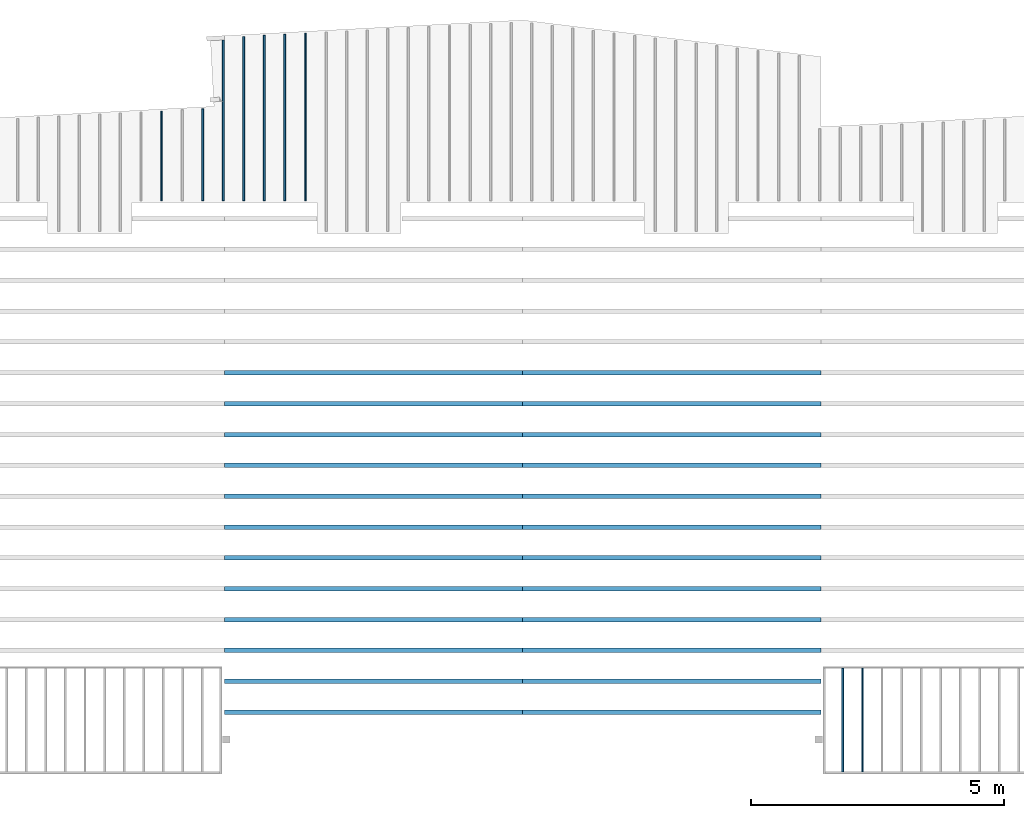
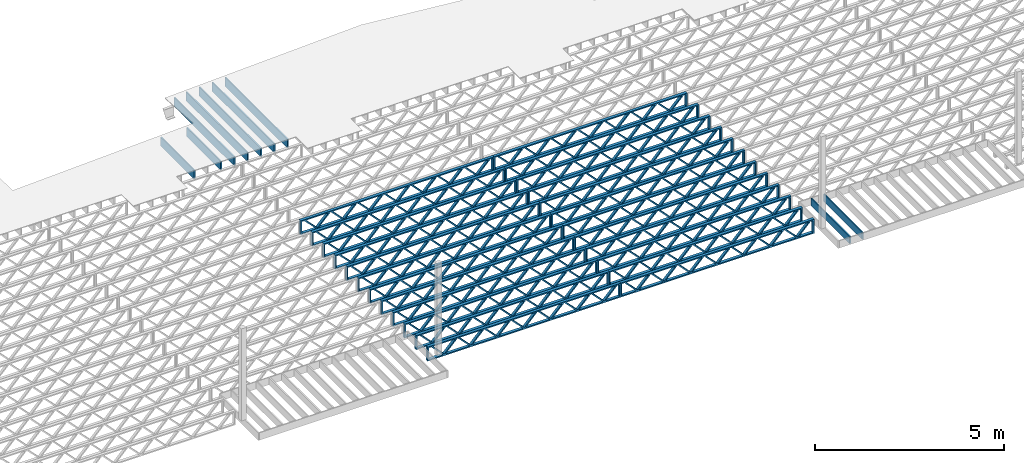
# One storey, part 6 of 13: 33 beams, 4 elements without a shape of their own.
"""IFC4 building model written with IfcOpenShell, lengths in feet."""

from ifc_helpers import new_model, entity, si_unit, converted_unit, derived_unit, direction, frame, frame_2d, origin, origin_2d_with_axis, place, context, subcontext, project, spatial, rectangle, extrude, source, transform, mapped, material, material_profile, profile_set, profile_usage, type_object, type_shapes, element, aggregate, save


model = new_model("IFC4")

# Units and contexts
model_context_1 = context("Model", 3, precision=0.0001, world=origin(), true_north=direction((6.12303176911189e-17, 1.0)))
model_context_2 = context("Model", 3, precision=0.0001, world=origin(), true_north=direction((6.12303176911189e-17, 1.0)))
body_context = subcontext(model_context_2, "Body", "Model", "MODEL_VIEW")
ifc_project = project(units=[converted_unit("LENGTHUNIT", "FOOT", entity("IfcRatioMeasure", 0.3048), si_unit("LENGTHUNIT", "METRE"), dimensions=[1, 0, 0, 0, 0, 0, 0]), converted_unit("AREAUNIT", "SQUARE FOOT", entity("IfcRatioMeasure", 0.09290304), si_unit("AREAUNIT", "SQUARE_METRE"), dimensions=[2, 0, 0, 0, 0, 0, 0]), converted_unit("VOLUMEUNIT", "CUBIC FOOT", entity("IfcRatioMeasure", 0.028316846592), si_unit("VOLUMEUNIT", "CUBIC_METRE"), dimensions=[3, 0, 0, 0, 0, 0, 0]), converted_unit("PLANEANGLEUNIT", "DEGREE", entity("IfcRatioMeasure", 0.0174532925199433), si_unit("PLANEANGLEUNIT", "RADIAN"), dimensions=[0, 0, 0, 0, 0, 0, 0]), si_unit("MASSUNIT", "GRAM", prefix="KILO"), derived_unit("MASSDENSITYUNIT", [(si_unit("MASSUNIT", "GRAM", prefix="KILO"), 1), (si_unit("LENGTHUNIT", "METRE"), -3)]), derived_unit("MOMENTOFINERTIAUNIT", [(si_unit("LENGTHUNIT", "METRE"), 4)]), si_unit("TIMEUNIT", "SECOND"), si_unit("FREQUENCYUNIT", "HERTZ"), si_unit("THERMODYNAMICTEMPERATUREUNIT", "DEGREE_CELSIUS"), derived_unit("THERMALTRANSMITTANCEUNIT", [(si_unit("MASSUNIT", "GRAM", prefix="KILO"), 1), (si_unit("THERMODYNAMICTEMPERATUREUNIT", "KELVIN"), -1), (si_unit("TIMEUNIT", "SECOND"), -3)]), derived_unit("VOLUMETRICFLOWRATEUNIT", [(si_unit("LENGTHUNIT", "METRE"), 3), (si_unit("TIMEUNIT", "SECOND"), -1)]), si_unit("ELECTRICCURRENTUNIT", "AMPERE"), si_unit("ELECTRICVOLTAGEUNIT", "VOLT"), si_unit("POWERUNIT", "WATT"), si_unit("FORCEUNIT", "NEWTON"), si_unit("ILLUMINANCEUNIT", "LUX"), si_unit("LUMINOUSFLUXUNIT", "LUMEN"), si_unit("LUMINOUSINTENSITYUNIT", "CANDELA"), derived_unit("USERDEFINED", [(si_unit("MASSUNIT", "GRAM", prefix="KILO"), -1), (si_unit("LENGTHUNIT", "METRE"), -2), (si_unit("TIMEUNIT", "SECOND"), 3), (si_unit("LUMINOUSFLUXUNIT", "LUMEN"), 1)]), derived_unit("LINEARVELOCITYUNIT", [(si_unit("LENGTHUNIT", "METRE"), 1), (si_unit("TIMEUNIT", "SECOND"), -1)]), si_unit("PRESSUREUNIT", "PASCAL"), derived_unit("USERDEFINED", [(si_unit("LENGTHUNIT", "METRE"), -2), (si_unit("MASSUNIT", "GRAM", prefix="KILO"), 1), (si_unit("TIMEUNIT", "SECOND"), -2)]), derived_unit("LINEARFORCEUNIT", [(si_unit("MASSUNIT", "GRAM", prefix="KILO"), 1), (si_unit("LENGTHUNIT", "METRE"), 1), (si_unit("TIMEUNIT", "SECOND"), -2), (si_unit("LENGTHUNIT", "METRE"), -1)]), derived_unit("PLANARFORCEUNIT", [(si_unit("MASSUNIT", "GRAM", prefix="KILO"), 1), (si_unit("LENGTHUNIT", "METRE"), 1), (si_unit("TIMEUNIT", "SECOND"), -2), (si_unit("LENGTHUNIT", "METRE"), -2)])], contexts=[model_context_1])

# Site, building, storey
site_placement = place(None, origin())
site = spatial("IfcSite", under=ifc_project, at=site_placement, CompositionType="ELEMENT")
building_placement = place(site_placement, origin())
building = spatial("IfcBuilding", under=site, at=building_placement, CompositionType="ELEMENT")
storey_placement = place(building_placement, frame((0.0, 0.0, 21.46875)))
storey = spatial("IfcBuildingStorey", under=building, at=storey_placement, Name="3RD FLOOR", CompositionType="ELEMENT", Elevation=21.46875)

# Assembly, beams
assembly_1_placement = place(storey_placement, origin())
assembly_1 = element("IfcElementAssembly", 1, at=assembly_1_placement, inside=storey, Name="Structural Beam System:Structural Framing System", ObjectType="Structural Beam System:Structural Framing System", AssemblyPlace="NOTDEFINED", PredefinedType="BEAM_GRID")
ifc_material_1 = material(Name="WOOD TRUSS", Category="Materials")
ifc_material_profile_1 = material_profile(ifc_material_1, rectangle(XDim=1.73473973950632, YDim=0.125, at=frame_2d((-1.11022302462516e-16, 8.32667268468867e-17), x_axis=(1.0, 0.0))))
ifc_material_profile_2 = material_profile(ifc_material_1, rectangle(XDim=1.73473973950633, YDim=0.125, at=frame_2d((-1.11022302462516e-16, 8.32667268468867e-17), x_axis=(1.0, 0.0))))
ifc_material_profile_3 = material_profile(ifc_material_1, rectangle(XDim=1.73473973950632, YDim=0.125, at=frame_2d((-5.55111512312578e-17, 1.38777878078145e-16), x_axis=(1.0, 0.0))))
ifc_material_profile_4 = material_profile(ifc_material_1, rectangle(XDim=1.73473973950633, YDim=0.125, at=frame_2d((-1.11022302462516e-16, 8.32667268468867e-17), x_axis=(1.0, 0.0))))
ifc_material_profile_5 = material_profile(ifc_material_1, rectangle(XDim=1.73473973950632, YDim=0.125, at=frame_2d((-1.11022302462516e-16, 8.32667268468867e-17), x_axis=(1.0, 0.0))))
ifc_material_profile_6 = material_profile(ifc_material_1, rectangle(XDim=1.73473973950633, YDim=0.125, at=frame_2d((-2.77555756156289e-16, 3.05311331771918e-16), x_axis=(1.0, 0.0))))
ifc_material_profile_7 = material_profile(ifc_material_1, rectangle(XDim=1.73473973950632, YDim=0.124999999999999, at=frame_2d((-3.88578058618805e-16, -2.4980018054066e-16), x_axis=(1.0, 0.0))))
ifc_material_profile_8 = material_profile(ifc_material_1, rectangle(XDim=1.73473973950633, YDim=0.125, at=frame_2d((2.77555756156289e-16, -3.05311331771918e-16), x_axis=(1.0, 0.0))))
ifc_material_profile_9 = material_profile(ifc_material_1, rectangle(XDim=1.73473973950632, YDim=0.124999999999999, at=frame_2d((-1.11022302462516e-16, 8.32667268468867e-17), x_axis=(1.0, 0.0))))
ifc_material_profile_10 = material_profile(ifc_material_1, rectangle(XDim=1.73473973950633, YDim=0.125, at=origin_2d_with_axis()))
ifc_material_profile_11 = material_profile(ifc_material_1, rectangle(XDim=0.124999999999982, YDim=0.291666666666668, at=origin_2d_with_axis()))
ifc_material_profile_12 = material_profile(ifc_material_1, rectangle(XDim=0.124999999999932, YDim=0.291666666666664, at=origin_2d_with_axis()))
ifc_material_profile_13 = material_profile(ifc_material_1, rectangle(XDim=1.25000000000002, YDim=0.29166666666667, at=origin_2d_with_axis()))
ifc_material_profile_14 = material_profile(ifc_material_1, rectangle(XDim=1.25000000000004, YDim=0.291666666666667, at=origin_2d_with_axis()))
ifc_profile_set_1 = profile_set([ifc_material_profile_1, ifc_material_profile_2, ifc_material_profile_3, ifc_material_profile_4, ifc_material_profile_5, ifc_material_profile_6, ifc_material_profile_7, ifc_material_profile_8, ifc_material_profile_9, ifc_material_profile_10, ifc_material_profile_11, ifc_material_profile_12, ifc_material_profile_13, ifc_material_profile_14])
ifc_profile_usage_1 = profile_usage(ifc_profile_set_1, cardinal=8)
beam_type_1 = type_object("IfcBeamType", PredefinedType="BEAM", material=ifc_profile_set_1)
shared_shape_1 = source(origin(), body_context, "Body", "SweptSolid", [
    extrude(rectangle(XDim=1.73473973950632, YDim=0.124999999999999, at=frame_2d((5.55111512312578e-16, 7.21644966006352e-16), x_axis=(1.0, 0.0))), frame((5.95847627016997, -0.145833333333334, 0.0), z_axis=(0.0, 1.0, 0.0), x_axis=(0.693383046997606, 0.0, 0.720569184836762)), (0.0, 0.0, 1.0), 0.291666666666667),
    extrude(rectangle(XDim=1.73473973950633, YDim=0.125, at=origin_2d_with_axis()), frame((4.7081903964967, -0.145833333333334, 0.0), z_axis=(0.0, 1.0, 0.0), x_axis=(0.69338304699761, 0.0, -0.720569184836758)), (0.0, 0.0, 1.0), 0.291666666666666),
    extrude(rectangle(XDim=1.73473973950632, YDim=0.125, at=frame_2d((2.22044604925031e-16, 3.88578058618805e-16), x_axis=(1.0, 0.0))), frame((3.29180960350347, -0.145833333333334, 0.0), z_axis=(0.0, 1.0, 0.0), x_axis=(0.693383046997606, 0.0, 0.720569184836762)), (0.0, 0.0, 1.0), 0.291666666666667),
    extrude(rectangle(XDim=1.73473973950633, YDim=0.125, at=frame_2d((1.11022302462516e-16, -8.32667268468867e-17), x_axis=(1.0, 0.0))), frame((2.0415237298302, -0.145833333333334, 0.0), z_axis=(0.0, 1.0, 0.0), x_axis=(0.69338304699761, 0.0, -0.720569184836758)), (0.0, 0.0, 1.0), 0.291666666666667),
    extrude(rectangle(XDim=1.73473973950632, YDim=0.125, at=frame_2d((-5.55111512312578e-17, 1.38777878078145e-16), x_axis=(1.0, 0.0))), frame((0.625142936836964, -0.145833333333334, 0.0), z_axis=(0.0, 1.0, 0.0), x_axis=(0.693383046997606, 0.0, 0.720569184836762)), (0.0, 0.0, 1.0), 0.291666666666667),
    extrude(rectangle(XDim=1.73473973950633, YDim=0.125, at=frame_2d((-1.11022302462516e-16, 8.32667268468867e-17), x_axis=(1.0, 0.0))), frame((-0.625142936836306, -0.145833333333334, 0.0), z_axis=(0.0, 1.0, 0.0), x_axis=(0.69338304699761, 0.0, -0.720569184836758)), (0.0, 0.0, 1.0), 0.291666666666667),
    extrude(rectangle(XDim=1.73473973950632, YDim=0.125, at=frame_2d((-1.11022302462516e-16, 8.32667268468867e-17), x_axis=(1.0, 0.0))), frame((-2.04152372982954, -0.145833333333334, 0.0), z_axis=(0.0, 1.0, 0.0), x_axis=(0.693383046997606, 0.0, 0.720569184836762)), (0.0, 0.0, 1.0), 0.291666666666667),
    extrude(rectangle(XDim=1.73473973950633, YDim=0.125, at=origin_2d_with_axis()), frame((-3.29180960350281, -0.145833333333334, 0.0), z_axis=(0.0, 1.0, 0.0), x_axis=(0.69338304699761, 0.0, -0.720569184836758)), (0.0, 0.0, 1.0), 0.291666666666667),
    extrude(rectangle(XDim=1.73473973950632, YDim=0.124999999999999, at=frame_2d((-1.11022302462516e-16, 8.32667268468867e-17), x_axis=(1.0, 0.0))), frame((-4.70819039649604, -0.145833333333334, 0.0), z_axis=(0.0, 1.0, 0.0), x_axis=(0.693383046997606, 0.0, 0.720569184836762)), (0.0, 0.0, 1.0), 0.291666666666667),
    extrude(rectangle(XDim=1.73473973950633, YDim=0.125, at=frame_2d((-5.55111512312578e-16, 6.38378239159465e-16), x_axis=(1.0, 0.0))), frame((-5.95847627016931, -0.145833333333334, 0.0), z_axis=(0.0, 1.0, 0.0), x_axis=(0.69338304699761, 0.0, -0.720569184836758)), (0.0, 0.0, 1.0), 0.291666666666666),
    extrude(rectangle(XDim=1.73473973950632, YDim=0.125, at=frame_2d((-7.21644966006352e-16, -5.82867087928207e-16), x_axis=(1.0, 0.0))), frame((8.62514293683647, -0.145833333333334, 0.0), z_axis=(0.0, 1.0, 0.0), x_axis=(0.693383046997607, 0.0, 0.720569184836761)), (0.0, 0.0, 1.0), 0.291666666666667),
    extrude(rectangle(XDim=1.73473973950633, YDim=0.125, at=origin_2d_with_axis()), frame((7.3748570631632, -0.145833333333334, 0.0), z_axis=(0.0, 1.0, 0.0), x_axis=(0.69338304699761, 0.0, -0.720569184836758)), (0.0, 0.0, 1.0), 0.291666666666666),
    extrude(rectangle(XDim=1.73473973950632, YDim=0.124999999999999, at=frame_2d((-1.11022302462516e-16, 8.32667268468867e-17), x_axis=(1.0, 0.0))), frame((-7.37485706316255, -0.145833333333334, 0.0), z_axis=(0.0, 1.0, 0.0), x_axis=(0.693383046997606, 0.0, 0.720569184836762)), (0.0, 0.0, 1.0), 0.291666666666667),
    extrude(rectangle(XDim=1.73473973950633, YDim=0.125, at=origin_2d_with_axis()), frame((-8.62514293683582, -0.145833333333334, 0.0), z_axis=(0.0, 1.0, 0.0), x_axis=(0.69338304699761, 0.0, -0.720569184836758)), (0.0, 0.0, 1.0), 0.291666666666666),
    extrude(rectangle(XDim=0.124999999999982, YDim=0.291666666666668, at=origin_2d_with_axis()), frame((-9.66666666666609, 0.0, 0.687500000000054), z_axis=(1.0, 0.0, 0.0), x_axis=(0.0, 0.0, -1.0)), (0.0, 0.0, 1.0), 19.3333333333322),
    extrude(rectangle(XDim=0.124999999999932, YDim=0.291666666666664, at=origin_2d_with_axis()), frame((-9.66666666666588, 0.0, -0.687499999999984), z_axis=(1.0, 0.0, 0.0), x_axis=(0.0, 0.0, -1.0)), (0.0, 0.0, 1.0), 19.333333333332),
    extrude(rectangle(XDim=1.25000000000002, YDim=0.29166666666667, at=origin_2d_with_axis()), frame((9.54166666666607, 0.0, 0.0), z_axis=(1.0, 0.0, 0.0), x_axis=(0.0, 0.0, -1.0)), (0.0, 0.0, 1.0), 0.12500000000002),
    extrude(rectangle(XDim=1.25000000000004, YDim=0.291666666666667, at=origin_2d_with_axis()), frame((-9.66666666666609, 0.0, 0.0), z_axis=(1.0, 0.0, 0.0), x_axis=(0.0, 0.0, -1.0)), (0.0, 0.0, 1.0), 0.125000000000023),
])
type_shapes(beam_type_1, [shared_shape_1])
beam_1_placement = place(assembly_1_placement, frame((-193.404827152229, 947.861934882651, -0.947916666666881)))
beam_1 = element("IfcBeam", 2, at=beam_1_placement, type_object=beam_type_1, material=ifc_profile_usage_1, PredefinedType="BEAM", context=body_context, shape_type="MappedRepresentation", body=[
    mapped(shared_shape_1, transform((0.0, 0.0, 0.0), scale=1.0)),
])
ifc_profile_usage_2 = profile_usage(ifc_profile_set_1, cardinal=8)
beam_2_placement = place(assembly_1_placement, frame((-193.404827152229, 945.861934882651, -0.947916666666881)))
beam_2 = element("IfcBeam", 3, at=beam_2_placement, type_object=beam_type_1, material=ifc_profile_usage_2, PredefinedType="BEAM", context=body_context, shape_type="MappedRepresentation", body=[
    mapped(shared_shape_1, transform((0.0, 0.0, 0.0), scale=1.0)),
])
ifc_profile_usage_3 = profile_usage(ifc_profile_set_1, cardinal=8)
beam_3_placement = place(assembly_1_placement, frame((-193.404827152229, 943.861934882651, -0.947916666666881)))
beam_3 = element("IfcBeam", 4, at=beam_3_placement, type_object=beam_type_1, material=ifc_profile_usage_3, PredefinedType="BEAM", context=body_context, shape_type="MappedRepresentation", body=[
    mapped(shared_shape_1, transform((0.0, 0.0, 0.0), scale=1.0)),
])
ifc_profile_usage_4 = profile_usage(ifc_profile_set_1, cardinal=8)
beam_4_placement = place(assembly_1_placement, frame((-193.404827152229, 941.861934882651, -0.947916666666881)))
beam_4 = element("IfcBeam", 5, at=beam_4_placement, type_object=beam_type_1, material=ifc_profile_usage_4, PredefinedType="BEAM", context=body_context, shape_type="MappedRepresentation", body=[
    mapped(shared_shape_1, transform((0.0, 0.0, 0.0), scale=1.0)),
])
ifc_profile_usage_5 = profile_usage(ifc_profile_set_1, cardinal=8)
beam_5_placement = place(assembly_1_placement, frame((-193.404827152229, 939.861934882651, -0.947916666666881)))
beam_5 = element("IfcBeam", 6, at=beam_5_placement, type_object=beam_type_1, material=ifc_profile_usage_5, PredefinedType="BEAM", context=body_context, shape_type="MappedRepresentation", body=[
    mapped(shared_shape_1, transform((0.0, 0.0, 0.0), scale=1.0)),
])
ifc_profile_usage_6 = profile_usage(ifc_profile_set_1, cardinal=8)
beam_6_placement = place(assembly_1_placement, frame((-193.404827152229, 937.861934882651, -0.947916666666881)))
beam_6 = element("IfcBeam", 7, at=beam_6_placement, type_object=beam_type_1, material=ifc_profile_usage_6, PredefinedType="BEAM", context=body_context, shape_type="MappedRepresentation", body=[
    mapped(shared_shape_1, transform((0.0, 0.0, 0.0), scale=1.0)),
])
ifc_profile_usage_7 = profile_usage(ifc_profile_set_1, cardinal=8)
beam_7_placement = place(assembly_1_placement, frame((-193.404827152229, 935.861934882651, -0.947916666666881)))
beam_7 = element("IfcBeam", 8, at=beam_7_placement, type_object=beam_type_1, material=ifc_profile_usage_7, PredefinedType="BEAM", context=body_context, shape_type="MappedRepresentation", body=[
    mapped(shared_shape_1, transform((0.0, 0.0, 0.0), scale=1.0)),
])
ifc_profile_usage_8 = profile_usage(ifc_profile_set_1, cardinal=8)
beam_8_placement = place(assembly_1_placement, frame((-193.404827152229, 933.861934882651, -0.947916666666881)))
beam_8 = element("IfcBeam", 9, at=beam_8_placement, type_object=beam_type_1, material=ifc_profile_usage_8, PredefinedType="BEAM", context=body_context, shape_type="MappedRepresentation", body=[
    mapped(shared_shape_1, transform((0.0, 0.0, 0.0), scale=1.0)),
])
ifc_profile_usage_9 = profile_usage(ifc_profile_set_1, cardinal=8)
beam_9_placement = place(assembly_1_placement, frame((-193.404827152229, 931.861934882651, -0.947916666666881)))
beam_9 = element("IfcBeam", 10, at=beam_9_placement, type_object=beam_type_1, material=ifc_profile_usage_9, PredefinedType="BEAM", context=body_context, shape_type="MappedRepresentation", body=[
    mapped(shared_shape_1, transform((0.0, 0.0, 0.0), scale=1.0)),
])
ifc_profile_usage_10 = profile_usage(ifc_profile_set_1, cardinal=8)
beam_10_placement = place(assembly_1_placement, frame((-193.404827152229, 929.861934882651, -0.947916666666881)))
beam_10 = element("IfcBeam", 11, at=beam_10_placement, type_object=beam_type_1, material=ifc_profile_usage_10, PredefinedType="BEAM", context=body_context, shape_type="MappedRepresentation", body=[
    mapped(shared_shape_1, transform((0.0, 0.0, 0.0), scale=1.0)),
])
ifc_profile_usage_11 = profile_usage(ifc_profile_set_1, cardinal=8)
beam_11_placement = place(assembly_1_placement, frame((-193.404827152229, 927.861934882651, -0.947916666666881)))
beam_11 = element("IfcBeam", 12, at=beam_11_placement, type_object=beam_type_1, material=ifc_profile_usage_11, PredefinedType="BEAM", context=body_context, shape_type="MappedRepresentation", body=[
    mapped(shared_shape_1, transform((0.0, 0.0, 0.0), scale=1.0)),
])
ifc_profile_usage_12 = profile_usage(ifc_profile_set_1, cardinal=8)
beam_12_placement = place(assembly_1_placement, frame((-193.404827152229, 925.861934882651, -0.947916666666881)))
beam_12 = element("IfcBeam", 13, at=beam_12_placement, type_object=beam_type_1, material=ifc_profile_usage_12, PredefinedType="BEAM", context=body_context, shape_type="MappedRepresentation", body=[
    mapped(shared_shape_1, transform((0.0, 0.0, 0.0), scale=1.0)),
])
aggregate(assembly_1, [beam_1, beam_2, beam_3, beam_4, beam_5, beam_6, beam_7, beam_8, beam_9, beam_10, beam_11, beam_12])

assembly_2_placement = place(storey_placement, origin())
assembly_2 = element("IfcElementAssembly", 14, at=assembly_2_placement, inside=storey, Name="Structural Beam System:Structural Framing System", ObjectType="Structural Beam System:Structural Framing System", AssemblyPlace="NOTDEFINED", PredefinedType="BEAM_GRID")
ifc_profile_usage_13 = profile_usage(ifc_profile_set_1, cardinal=8)
beam_13_placement = place(assembly_2_placement, frame((-212.738160485495, 947.861934882651, -0.947916666666881), z_axis=(0.0, 0.0, 1.0), x_axis=(-1.0, 0.0, 0.0)))
beam_13 = element("IfcBeam", 15, at=beam_13_placement, type_object=beam_type_1, material=ifc_profile_usage_13, PredefinedType="BEAM", context=body_context, shape_type="MappedRepresentation", body=[
    mapped(shared_shape_1, transform((0.0, 0.0, 0.0), scale=1.0)),
])
ifc_profile_usage_14 = profile_usage(ifc_profile_set_1, cardinal=8)
beam_14_placement = place(assembly_2_placement, frame((-212.738160485495, 945.861934882651, -0.947916666666881), z_axis=(0.0, 0.0, 1.0), x_axis=(-1.0, 0.0, 0.0)))
beam_14 = element("IfcBeam", 16, at=beam_14_placement, type_object=beam_type_1, material=ifc_profile_usage_14, PredefinedType="BEAM", context=body_context, shape_type="MappedRepresentation", body=[
    mapped(shared_shape_1, transform((0.0, 0.0, 0.0), scale=1.0)),
])
ifc_profile_usage_15 = profile_usage(ifc_profile_set_1, cardinal=8)
beam_15_placement = place(assembly_2_placement, frame((-212.738160485495, 943.861934882651, -0.947916666666881), z_axis=(0.0, 0.0, 1.0), x_axis=(-1.0, 0.0, 0.0)))
beam_15 = element("IfcBeam", 17, at=beam_15_placement, type_object=beam_type_1, material=ifc_profile_usage_15, PredefinedType="BEAM", context=body_context, shape_type="MappedRepresentation", body=[
    mapped(shared_shape_1, transform((0.0, 0.0, 0.0), scale=1.0)),
])
ifc_profile_usage_16 = profile_usage(ifc_profile_set_1, cardinal=8)
beam_16_placement = place(assembly_2_placement, frame((-212.738160485495, 941.861934882651, -0.947916666666881), z_axis=(0.0, 0.0, 1.0), x_axis=(-1.0, 0.0, 0.0)))
beam_16 = element("IfcBeam", 18, at=beam_16_placement, type_object=beam_type_1, material=ifc_profile_usage_16, PredefinedType="BEAM", context=body_context, shape_type="MappedRepresentation", body=[
    mapped(shared_shape_1, transform((0.0, 0.0, 0.0), scale=1.0)),
])
ifc_profile_usage_17 = profile_usage(ifc_profile_set_1, cardinal=8)
beam_17_placement = place(assembly_2_placement, frame((-212.738160485495, 939.861934882651, -0.947916666666881), z_axis=(0.0, 0.0, 1.0), x_axis=(-1.0, 0.0, 0.0)))
beam_17 = element("IfcBeam", 19, at=beam_17_placement, type_object=beam_type_1, material=ifc_profile_usage_17, PredefinedType="BEAM", context=body_context, shape_type="MappedRepresentation", body=[
    mapped(shared_shape_1, transform((0.0, 0.0, 0.0), scale=1.0)),
])
ifc_profile_usage_18 = profile_usage(ifc_profile_set_1, cardinal=8)
beam_18_placement = place(assembly_2_placement, frame((-212.738160485495, 937.861934882651, -0.947916666666881), z_axis=(0.0, 0.0, 1.0), x_axis=(-1.0, 0.0, 0.0)))
beam_18 = element("IfcBeam", 20, at=beam_18_placement, type_object=beam_type_1, material=ifc_profile_usage_18, PredefinedType="BEAM", context=body_context, shape_type="MappedRepresentation", body=[
    mapped(shared_shape_1, transform((0.0, 0.0, 0.0), scale=1.0)),
])
ifc_profile_usage_19 = profile_usage(ifc_profile_set_1, cardinal=8)
beam_19_placement = place(assembly_2_placement, frame((-212.738160485495, 935.861934882651, -0.947916666666881), z_axis=(0.0, 0.0, 1.0), x_axis=(-1.0, 0.0, 0.0)))
beam_19 = element("IfcBeam", 21, at=beam_19_placement, type_object=beam_type_1, material=ifc_profile_usage_19, PredefinedType="BEAM", context=body_context, shape_type="MappedRepresentation", body=[
    mapped(shared_shape_1, transform((0.0, 0.0, 0.0), scale=1.0)),
])
ifc_profile_usage_20 = profile_usage(ifc_profile_set_1, cardinal=8)
beam_20_placement = place(assembly_2_placement, frame((-212.738160485495, 933.861934882651, -0.947916666666881), z_axis=(0.0, 0.0, 1.0), x_axis=(-1.0, 0.0, 0.0)))
beam_20 = element("IfcBeam", 22, at=beam_20_placement, type_object=beam_type_1, material=ifc_profile_usage_20, PredefinedType="BEAM", context=body_context, shape_type="MappedRepresentation", body=[
    mapped(shared_shape_1, transform((0.0, 0.0, 0.0), scale=1.0)),
])
ifc_profile_usage_21 = profile_usage(ifc_profile_set_1, cardinal=8)
beam_21_placement = place(assembly_2_placement, frame((-212.738160485495, 931.861934882651, -0.947916666666881), z_axis=(0.0, 0.0, 1.0), x_axis=(-1.0, 0.0, 0.0)))
beam_21 = element("IfcBeam", 23, at=beam_21_placement, type_object=beam_type_1, material=ifc_profile_usage_21, PredefinedType="BEAM", context=body_context, shape_type="MappedRepresentation", body=[
    mapped(shared_shape_1, transform((0.0, 0.0, 0.0), scale=1.0)),
])
ifc_profile_usage_22 = profile_usage(ifc_profile_set_1, cardinal=8)
beam_22_placement = place(assembly_2_placement, frame((-212.738160485495, 929.861934882651, -0.947916666666881), z_axis=(0.0, 0.0, 1.0), x_axis=(-1.0, 0.0, 0.0)))
beam_22 = element("IfcBeam", 24, at=beam_22_placement, type_object=beam_type_1, material=ifc_profile_usage_22, PredefinedType="BEAM", context=body_context, shape_type="MappedRepresentation", body=[
    mapped(shared_shape_1, transform((0.0, 0.0, 0.0), scale=1.0)),
])
ifc_profile_usage_23 = profile_usage(ifc_profile_set_1, cardinal=8)
beam_23_placement = place(assembly_2_placement, frame((-212.738160485495, 927.861934882651, -0.947916666666881), z_axis=(0.0, 0.0, 1.0), x_axis=(-1.0, 0.0, 0.0)))
beam_23 = element("IfcBeam", 25, at=beam_23_placement, type_object=beam_type_1, material=ifc_profile_usage_23, PredefinedType="BEAM", context=body_context, shape_type="MappedRepresentation", body=[
    mapped(shared_shape_1, transform((0.0, 0.0, 0.0), scale=1.0)),
])
ifc_profile_usage_24 = profile_usage(ifc_profile_set_1, cardinal=8)
beam_24_placement = place(assembly_2_placement, frame((-212.738160485495, 925.861934882651, -0.947916666666881), z_axis=(0.0, 0.0, 1.0), x_axis=(-1.0, 0.0, 0.0)))
beam_24 = element("IfcBeam", 26, at=beam_24_placement, type_object=beam_type_1, material=ifc_profile_usage_24, PredefinedType="BEAM", context=body_context, shape_type="MappedRepresentation", body=[
    mapped(shared_shape_1, transform((0.0, 0.0, 0.0), scale=1.0)),
])
aggregate(assembly_2, [beam_13, beam_14, beam_15, beam_16, beam_17, beam_18, beam_19, beam_20, beam_21, beam_22, beam_23, beam_24])

assembly_3_placement = place(storey_placement, origin())
assembly_3 = element("IfcElementAssembly", 27, at=assembly_3_placement, inside=storey, Name="Structural Beam System:Structural Framing System", ObjectType="Structural Beam System:Structural Framing System", AssemblyPlace="NOTDEFINED", PredefinedType="BEAM_GRID")
ifc_material_2 = material(Category="Materials")
ifc_material_profile_15 = material_profile(ifc_material_2, rectangle(XDim=0.770833333333333, YDim=0.124999999999994, at=frame_2d((-5.55111512312578e-17, 0.0), x_axis=(1.0, 0.0))))
ifc_profile_set_2 = profile_set([ifc_material_profile_15])
ifc_profile_usage_25 = profile_usage(ifc_profile_set_2, cardinal=8)
beam_type_2 = type_object("IfcBeamType", PredefinedType="BEAM", material=ifc_profile_set_2)
shared_shape_2 = source(origin(), body_context, "Body", "SweptSolid", [
    extrude(rectangle(XDim=0.770833333333333, YDim=0.124999999999994, at=frame_2d((-5.55111512312578e-17, 0.0), x_axis=(1.0, 0.0))), frame((-3.35416666666737, 0.0, 0.0), z_axis=(1.0, 0.0, 0.0), x_axis=(0.0, 0.0, -1.0)), (0.0, 0.0, 1.0), 6.70833333333462),
])
type_shapes(beam_type_2, [shared_shape_2])
beam_25_placement = place(assembly_3_placement, frame((-181.037726457813, 925.341101549318, -0.645833333333474), z_axis=(0.0, 0.0, 1.0), x_axis=(0.0, 1.0, 0.0)))
beam_25 = element("IfcBeam", 28, at=beam_25_placement, type_object=beam_type_2, material=ifc_profile_usage_25, PredefinedType="BEAM", context=body_context, shape_type="MappedRepresentation", body=[
    mapped(shared_shape_2, transform((0.0, 0.0, 0.0), scale=1.0)),
])
ifc_profile_usage_26 = profile_usage(ifc_profile_set_2, cardinal=8)
beam_26_placement = place(assembly_3_placement, frame((-182.304610138371, 925.341101549319, -0.645833333333474), z_axis=(0.0, 0.0, 1.0), x_axis=(0.0, 1.0, 0.0)))
beam_26 = element("IfcBeam", 29, at=beam_26_placement, type_object=beam_type_2, material=ifc_profile_usage_26, PredefinedType="BEAM", context=body_context, shape_type="MappedRepresentation", body=[
    mapped(shared_shape_2, transform((0.0, 0.0, 0.0), scale=1.0)),
])
aggregate(assembly_3, [beam_25, beam_26])

assembly_4_placement = place(storey_placement, origin())
assembly_4 = element("IfcElementAssembly", 30, at=assembly_4_placement, inside=storey, Name="Structural Beam System:Structural Framing System", ObjectType="Structural Beam System:Structural Framing System", AssemblyPlace="NOTDEFINED", PredefinedType="BEAM_GRID")
ifc_material_profile_16 = material_profile(ifc_material_2, rectangle(XDim=0.9375, YDim=0.125000000000011, at=origin_2d_with_axis()))
ifc_profile_set_3 = profile_set([ifc_material_profile_16])
ifc_profile_usage_27 = profile_usage(ifc_profile_set_3, cardinal=8)
beam_type_3 = type_object("IfcBeamType", PredefinedType="BEAM", material=ifc_profile_set_3)
shared_shape_3 = source(origin(), body_context, "Body", "SweptSolid", [
    extrude(rectangle(XDim=0.9375, YDim=0.125000000000011, at=origin_2d_with_axis()), frame((-5.35190130957301, 0.0, 0.0), z_axis=(1.0, 0.0, 0.0), x_axis=(0.0, 0.0, -1.0)), (0.0, 0.0, 1.0), 10.703802619146),
])
type_shapes(beam_type_3, [shared_shape_3])
beam_27_placement = place(assembly_4_placement, frame((-219.810956052701, 964.381418830847, -0.729166666666714), z_axis=(0.0, 0.0, 1.0), x_axis=(0.0, 1.0, 0.0)))
beam_27 = element("IfcBeam", 31, at=beam_27_placement, type_object=beam_type_3, material=ifc_profile_usage_27, PredefinedType="BEAM", context=body_context, shape_type="MappedRepresentation", body=[
    mapped(shared_shape_3, transform((0.0, 0.0, 0.0), scale=1.0)),
])
ifc_profile_usage_28 = profile_usage(ifc_profile_set_3, cardinal=8)
beam_type_4 = type_object("IfcBeamType", PredefinedType="BEAM", material=ifc_profile_set_3)
shared_shape_4 = source(origin(), body_context, "Body", "SweptSolid", [
    extrude(rectangle(XDim=0.9375, YDim=0.125000000000011, at=origin_2d_with_axis()), frame((-5.31696262266729, 0.0, 0.0), z_axis=(1.0, 0.0, 0.0), x_axis=(0.0, 0.0, -1.0)), (0.0, 0.0, 1.0), 10.6339252453346),
])
type_shapes(beam_type_4, [shared_shape_4])
beam_28_placement = place(assembly_4_placement, frame((-221.144289386034, 964.346480478709, -0.729166666666714), z_axis=(0.0, 0.0, 1.0), x_axis=(0.0, 1.0, 0.0)))
beam_28 = element("IfcBeam", 32, at=beam_28_placement, type_object=beam_type_4, material=ifc_profile_usage_28, PredefinedType="BEAM", context=body_context, shape_type="MappedRepresentation", body=[
    mapped(shared_shape_4, transform((0.0, 0.0, 0.0), scale=1.0)),
])
ifc_profile_usage_29 = profile_usage(ifc_profile_set_3, cardinal=8)
beam_type_5 = type_object("IfcBeamType", PredefinedType="BEAM", material=ifc_profile_set_3)
shared_shape_5 = source(origin(), body_context, "Body", "SweptSolid", [
    extrude(rectangle(XDim=0.9375, YDim=0.125000000000011, at=origin_2d_with_axis()), frame((-2.90325814564983, 0.0, 0.0), z_axis=(1.0, 0.0, 0.0), x_axis=(0.0, 0.0, -1.0)), (0.0, 0.0, 1.0), 5.80651629129966),
])
type_shapes(beam_type_5, [shared_shape_5])
beam_29_placement = place(assembly_4_placement, frame((-226.477622729298, 961.932777342, -0.729166666666714), z_axis=(0.0, 0.0, 1.0), x_axis=(0.0, 1.0, 0.0)))
beam_29 = element("IfcBeam", 33, at=beam_29_placement, type_object=beam_type_5, material=ifc_profile_usage_29, PredefinedType="BEAM", context=body_context, shape_type="MappedRepresentation", body=[
    mapped(shared_shape_5, transform((0.0, 0.0, 0.0), scale=1.0)),
])
ifc_profile_usage_30 = profile_usage(ifc_profile_set_3, cardinal=8)
beam_type_6 = type_object("IfcBeamType", PredefinedType="BEAM", material=ifc_profile_set_3)
shared_shape_6 = source(origin(), body_context, "Body", "SweptSolid", [
    extrude(rectangle(XDim=0.9375, YDim=0.125000000000011, at=origin_2d_with_axis()), frame((-2.97313544216473, 0.0, 0.0), z_axis=(1.0, 0.0, 0.0), x_axis=(0.0, 0.0, -1.0)), (0.0, 0.0, 1.0), 5.94627088432946),
])
type_shapes(beam_type_6, [shared_shape_6])
beam_30_placement = place(assembly_4_placement, frame((-223.810956052701, 962.002653967741, -0.729166666666714), z_axis=(0.0, 0.0, 1.0), x_axis=(0.0, 1.0, 0.0)))
beam_30 = element("IfcBeam", 34, at=beam_30_placement, type_object=beam_type_6, material=ifc_profile_usage_30, PredefinedType="BEAM", context=body_context, shape_type="MappedRepresentation", body=[
    mapped(shared_shape_6, transform((0.0, 0.0, 0.0), scale=1.0)),
])
ifc_profile_usage_31 = profile_usage(ifc_profile_set_3, cardinal=8)
beam_type_7 = type_object("IfcBeamType", PredefinedType="BEAM", material=ifc_profile_set_3)
shared_shape_7 = source(origin(), body_context, "Body", "SweptSolid", [
    extrude(rectangle(XDim=0.9375, YDim=0.125000000000011, at=origin_2d_with_axis()), frame((-5.31173131535462, 0.0, 0.0), z_axis=(1.0, 0.0, 0.0), x_axis=(0.0, 0.0, -1.0)), (0.0, 0.0, 1.0), 10.4022217638584),
])
type_shapes(beam_type_7, [shared_shape_7])
beam_31_placement = place(assembly_4_placement, frame((-222.477622719368, 964.34124950669, -0.729166666666714), z_axis=(0.0, 0.0, 1.0), x_axis=(0.0, 1.0, 0.0)))
beam_31 = element("IfcBeam", 35, at=beam_31_placement, type_object=beam_type_7, material=ifc_profile_usage_31, PredefinedType="BEAM", context=body_context, shape_type="MappedRepresentation", body=[
    mapped(shared_shape_7, transform((0.0, 0.0, 0.0), scale=1.0)),
])
ifc_profile_usage_32 = profile_usage(ifc_profile_set_3, cardinal=8)
beam_type_8 = type_object("IfcBeamType", PredefinedType="BEAM", material=ifc_profile_set_3)
shared_shape_8 = source(origin(), body_context, "Body", "SweptSolid", [
    extrude(rectangle(XDim=0.9375, YDim=0.125000000000011, at=origin_2d_with_axis()), frame((-5.38683999647867, 0.0, 0.0), z_axis=(1.0, 0.0, 0.0), x_axis=(0.0, 0.0, -1.0)), (0.0, 0.0, 1.0), 10.7736799929573),
])
type_shapes(beam_type_8, [shared_shape_8])
beam_32_placement = place(assembly_4_placement, frame((-218.477622719368, 964.416357182985, -0.729166666666714), z_axis=(0.0, 0.0, 1.0), x_axis=(0.0, 1.0, 0.0)))
beam_32 = element("IfcBeam", 36, at=beam_32_placement, type_object=beam_type_8, material=ifc_profile_usage_32, PredefinedType="BEAM", context=body_context, shape_type="MappedRepresentation", body=[
    mapped(shared_shape_8, transform((0.0, 0.0, 0.0), scale=1.0)),
])
ifc_profile_usage_33 = profile_usage(ifc_profile_set_3, cardinal=8)
beam_type_9 = type_object("IfcBeamType", PredefinedType="BEAM", material=ifc_profile_set_3)
shared_shape_9 = source(origin(), body_context, "Body", "SweptSolid", [
    extrude(rectangle(XDim=0.9375, YDim=0.125000000000011, at=origin_2d_with_axis()), frame((-5.42177868338433, 0.0, 0.0), z_axis=(1.0, 0.0, 0.0), x_axis=(0.0, 0.0, -1.0)), (0.0, 0.0, 1.0), 10.8435573667687),
])
type_shapes(beam_type_9, [shared_shape_9])
beam_33_placement = place(assembly_4_placement, frame((-217.144289386034, 964.451295535123, -0.729166666666714), z_axis=(0.0, 0.0, 1.0), x_axis=(0.0, 1.0, 0.0)))
beam_33 = element("IfcBeam", 37, at=beam_33_placement, type_object=beam_type_9, material=ifc_profile_usage_33, PredefinedType="BEAM", context=body_context, shape_type="MappedRepresentation", body=[
    mapped(shared_shape_9, transform((0.0, 0.0, 0.0), scale=1.0)),
])
aggregate(assembly_4, [beam_27, beam_28, beam_29, beam_30, beam_31, beam_32, beam_33])

save(model, "model.ifc")
